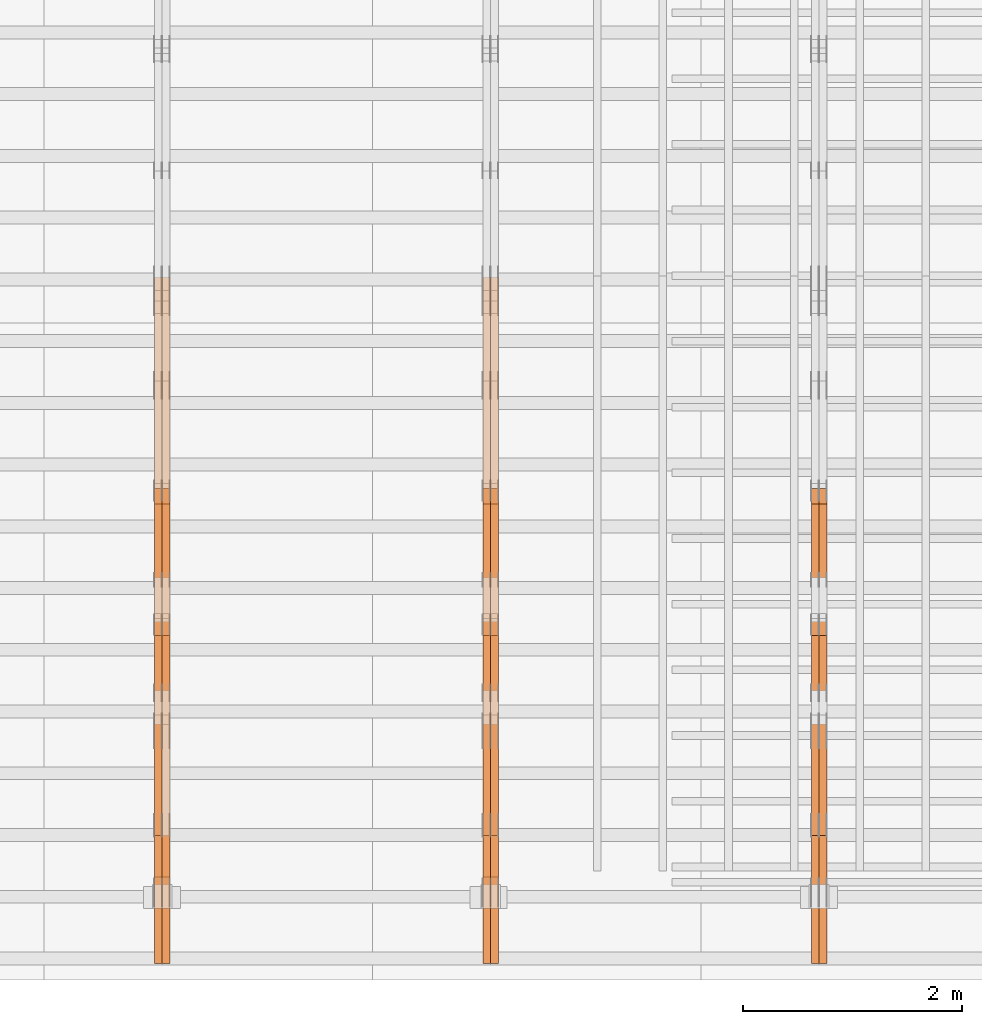
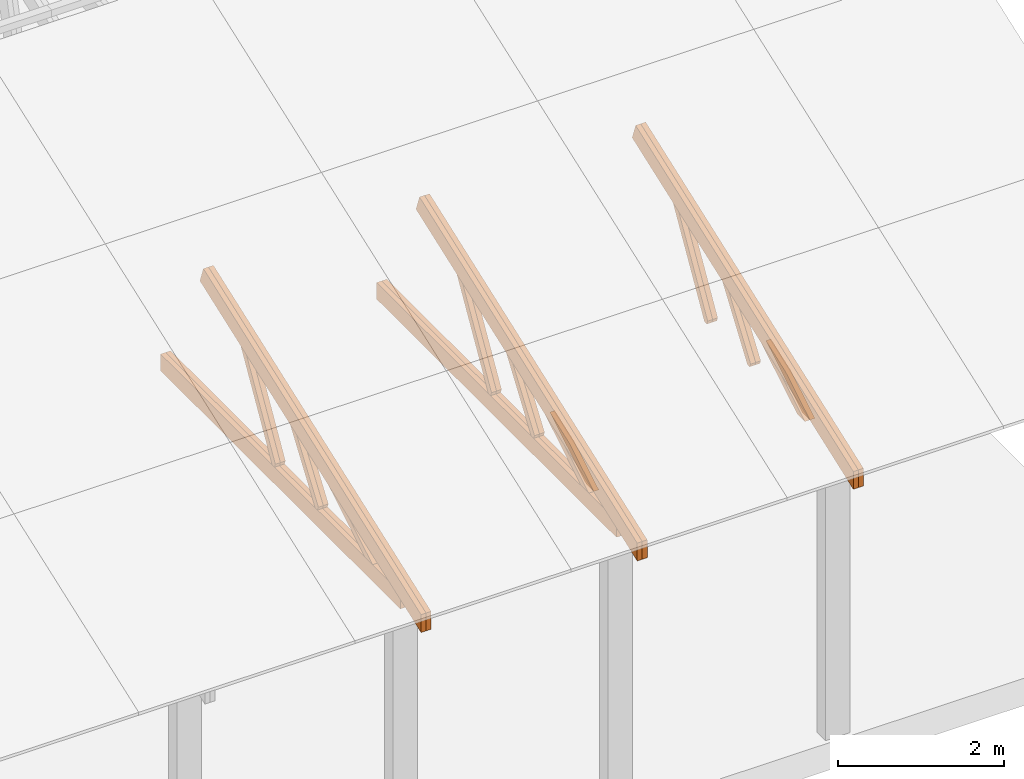
# One storey, part 47 of 189: 27 proxies.
"""IFC2X3 building model written with IfcOpenShell, lengths in millimetres."""

from ifc_helpers import new_model, entity, si_unit, converted_unit, derived_unit, direction, frame, origin, place, context, subcontext, project, spatial, polyline, outline, extrude, source, transform, mapped, material, type_object, type_shapes, element, save


model = new_model("IFC2X3")

# Units and contexts
model_context = context("Model", 3, precision=0.01, world=origin(), true_north=direction((6.12303176911189e-17, 1.0)))
body_context = subcontext(model_context, "Body", "Model", "MODEL_VIEW")
ifc_project = project(units=[si_unit("LENGTHUNIT", "METRE", prefix="MILLI"), si_unit("AREAUNIT", "SQUARE_METRE"), si_unit("VOLUMEUNIT", "CUBIC_METRE"), converted_unit("PLANEANGLEUNIT", "DEGREE", entity("IfcRatioMeasure", 0.0174532925199433), si_unit("PLANEANGLEUNIT", "RADIAN"), dimensions=[0, 0, 0, 0, 0, 0, 0]), si_unit("MASSUNIT", "GRAM", prefix="KILO"), derived_unit("MASSDENSITYUNIT", [(si_unit("MASSUNIT", "GRAM", prefix="KILO"), 1), (si_unit("LENGTHUNIT", "METRE"), -3)]), si_unit("TIMEUNIT", "SECOND"), si_unit("FREQUENCYUNIT", "HERTZ"), si_unit("THERMODYNAMICTEMPERATUREUNIT", "DEGREE_CELSIUS"), derived_unit("THERMALTRANSMITTANCEUNIT", [(si_unit("MASSUNIT", "GRAM", prefix="KILO"), 1), (si_unit("THERMODYNAMICTEMPERATUREUNIT", "KELVIN"), -1), (si_unit("TIMEUNIT", "SECOND"), -3)]), derived_unit("VOLUMETRICFLOWRATEUNIT", [(si_unit("LENGTHUNIT", "METRE"), 3), (si_unit("TIMEUNIT", "SECOND"), -1)]), si_unit("ELECTRICCURRENTUNIT", "AMPERE"), si_unit("ELECTRICVOLTAGEUNIT", "VOLT"), si_unit("POWERUNIT", "WATT"), si_unit("FORCEUNIT", "NEWTON"), si_unit("ILLUMINANCEUNIT", "LUX"), si_unit("LUMINOUSFLUXUNIT", "LUMEN"), si_unit("LUMINOUSINTENSITYUNIT", "CANDELA"), derived_unit("USERDEFINED", [(si_unit("MASSUNIT", "GRAM", prefix="KILO"), -1), (si_unit("LENGTHUNIT", "METRE"), -2), (si_unit("TIMEUNIT", "SECOND"), 3), (si_unit("LUMINOUSFLUXUNIT", "LUMEN"), 1)]), derived_unit("LINEARVELOCITYUNIT", [(si_unit("LENGTHUNIT", "METRE"), 1), (si_unit("TIMEUNIT", "SECOND"), -1)]), si_unit("PRESSUREUNIT", "PASCAL"), derived_unit("USERDEFINED", [(si_unit("LENGTHUNIT", "METRE"), -2), (si_unit("MASSUNIT", "GRAM", prefix="KILO"), 1), (si_unit("TIMEUNIT", "SECOND"), -2)])], contexts=[model_context])

# Site, building, storey
site_placement = place(None, origin())
site = spatial("IfcSite", under=ifc_project, at=site_placement, CompositionType="ELEMENT")
building_placement = place(site_placement, origin())
building = spatial("IfcBuilding", under=site, at=building_placement, CompositionType="ELEMENT")
storey_placement = place(building_placement, origin())
storey = spatial("IfcBuildingStorey", under=building, at=storey_placement, Name="Default", CompositionType="ELEMENT", Elevation=0.0)

# Proxies
ifc_material_1 = material(Name="IfcSurfaceStyle #239684")
building_element_proxy_type_1 = type_object("IfcBuildingElementProxyType", Name="T1-W11 239682", PredefinedType="NOTDEFINED", material=ifc_material_1)
shared_shape_1 = source(origin(), body_context, "Body", "SweptSolid", [
    extrude(outline(polyline([(593.358012843793, -552.565239103314), (742.388662259985, -552.565239103314), (-410.498749190676, 401.275038694583), (-462.246133468927, 382.44069706518), (-463.001792444175, 321.414742446865), (593.358012843793, -552.565239103314)])), frame((599.94412413079, 47.5003788877286, 0.0), z_axis=(0.0, 0.0, 1.0), x_axis=(0.770483455324544, 0.637459994879013, 0.0)), (0.0, 0.0, 1.0), 69.9999999999999),
])
type_shapes(building_element_proxy_type_1, [shared_shape_1])
proxy_1_placement = place(building_placement, frame((45300.0, 2983.26655629375, 269.034992751429), z_axis=(-1.0, 0.0, 0.0), x_axis=(0.0, 0.505995901100606, 0.862535882192379)))
element("IfcBuildingElementProxy", 1, at=proxy_1_placement, inside=storey, type_object=building_element_proxy_type_1, material=ifc_material_1, Name="T1-W11", context=body_context, shape_type="MappedRepresentation", body=[
    mapped(shared_shape_1, transform((0.0, 0.0, 0.0), scale=1.0)),
])
ifc_material_2 = material(Name="IfcSurfaceStyle #239618")
building_element_proxy_type_2 = type_object("IfcBuildingElementProxyType", Name="T1-W11 239616", PredefinedType="NOTDEFINED", material=ifc_material_2)
shared_shape_2 = source(origin(), body_context, "Body", "SweptSolid", [
    extrude(outline(polyline([(593.358012843793, -552.565239103314), (742.388662259985, -552.565239103314), (-410.498749190676, 401.275038694583), (-462.246133468927, 382.44069706518), (-463.001792444175, 321.414742446865), (593.358012843793, -552.565239103314)])), frame((599.94412413079, 47.5003788877286, 0.0), z_axis=(0.0, 0.0, 1.0), x_axis=(0.770483455324544, 0.637459994879013, 0.0)), (0.0, 0.0, 1.0), 69.9999999999999),
])
type_shapes(building_element_proxy_type_2, [shared_shape_2])
proxy_2_placement = place(building_placement, frame((45230.0, 2983.26655629375, 269.034992751429), z_axis=(-1.0, 0.0, 0.0), x_axis=(0.0, 0.505995901100606, 0.862535882192379)))
element("IfcBuildingElementProxy", 2, at=proxy_2_placement, inside=storey, type_object=building_element_proxy_type_2, material=ifc_material_2, Name="T1-W11", context=body_context, shape_type="MappedRepresentation", body=[
    mapped(shared_shape_2, transform((0.0, 0.0, 0.0), scale=1.0)),
])
ifc_material_3 = material(Name="IfcSurfaceStyle #239156")
building_element_proxy_type_3 = type_object("IfcBuildingElementProxyType", Name="T1-W13 239154", PredefinedType="NOTDEFINED", material=ifc_material_3)
shared_shape_3 = source(origin(), body_context, "Body", "SweptSolid", [
    extrude(outline(polyline([(404.740440720218, -341.48092914206), (570.336320797765, -341.48092914206), (-287.911826743206, 259.650691447848), (-342.395697357435, 239.820346030744), (-344.769237417342, 183.490820805529), (404.740440720218, -341.48092914206)])), frame((418.029573061951, 47.5005675782689, 0.0), z_axis=(0.0, 0.0, 1.0), x_axis=(0.819070847746389, 0.573692379565924, 0.0)), (0.0, 0.0, 1.0), 69.9999999999999),
])
type_shapes(building_element_proxy_type_3, [shared_shape_3])
proxy_3_placement = place(building_placement, frame((45300.0, 1951.16403402681, 272.239720286334), z_axis=(-1.0, 0.0, 0.0), x_axis=(0.0, 0.573462629043499, 0.819231721242848)))
element("IfcBuildingElementProxy", 3, at=proxy_3_placement, inside=storey, type_object=building_element_proxy_type_3, material=ifc_material_3, Name="T1-W13", context=body_context, shape_type="MappedRepresentation", body=[
    mapped(shared_shape_3, transform((0.0, 0.0, 0.0), scale=1.0)),
])
ifc_material_4 = material(Name="IfcSurfaceStyle #239090")
building_element_proxy_type_4 = type_object("IfcBuildingElementProxyType", Name="T1-W13 239088", PredefinedType="NOTDEFINED", material=ifc_material_4)
shared_shape_4 = source(origin(), body_context, "Body", "SweptSolid", [
    extrude(outline(polyline([(404.740440720218, -341.48092914206), (570.336320797765, -341.48092914206), (-287.911826743206, 259.650691447848), (-342.395697357435, 239.820346030744), (-344.769237417342, 183.490820805529), (404.740440720218, -341.48092914206)])), frame((418.029573061951, 47.5005675782689, 0.0), z_axis=(0.0, 0.0, 1.0), x_axis=(0.819070847746389, 0.573692379565924, 0.0)), (0.0, 0.0, 1.0), 69.9999999999999),
])
type_shapes(building_element_proxy_type_4, [shared_shape_4])
proxy_4_placement = place(building_placement, frame((45230.0, 1951.16403402681, 272.239720286334), z_axis=(-1.0, 0.0, 0.0), x_axis=(0.0, 0.573462629043499, 0.819231721242848)))
element("IfcBuildingElementProxy", 4, at=proxy_4_placement, inside=storey, type_object=building_element_proxy_type_4, material=ifc_material_4, Name="T1-W13", context=body_context, shape_type="MappedRepresentation", body=[
    mapped(shared_shape_4, transform((0.0, 0.0, 0.0), scale=1.0)),
])
ifc_material_5 = material(Name="IfcSurfaceStyle #238628")
building_element_proxy_type_5 = type_object("IfcBuildingElementProxyType", Name="T1-W12 238626", PredefinedType="NOTDEFINED", material=ifc_material_5)
shared_shape_5 = source(origin(), body_context, "Body", "SweptSolid", [
    extrude(outline(polyline([(-671.888430889784, -47.499785620702), (344.892972119224, -47.499785620702), (503.856463083211, 47.4997856207019), (-176.861004312651, 47.499785620702), (-671.888430889784, -47.499785620702)])), frame((503.857114243549, 47.5002636410509, 0.0), z_axis=(0.0, 0.0, 1.0), x_axis=(-1.0, 0.0, 0.0)), (0.0, 0.0, 1.0), 69.9999999999999),
])
type_shapes(building_element_proxy_type_5, [shared_shape_5])
proxy_5_placement = place(building_placement, frame((45300.0, 665.58122707747, 245.000076287477), z_axis=(-1.0, 0.0, 0.0), x_axis=(0.0, 0.858392121304013, 0.51299411895576)))
element("IfcBuildingElementProxy", 5, at=proxy_5_placement, inside=storey, type_object=building_element_proxy_type_5, material=ifc_material_5, Name="T1-W12", context=body_context, shape_type="MappedRepresentation", body=[
    mapped(shared_shape_5, transform((0.0, 0.0, 0.0), scale=1.0)),
])
ifc_material_6 = material(Name="IfcSurfaceStyle #238571")
building_element_proxy_type_6 = type_object("IfcBuildingElementProxyType", Name="T1-W12 238569", PredefinedType="NOTDEFINED", material=ifc_material_6)
shared_shape_6 = source(origin(), body_context, "Body", "SweptSolid", [
    extrude(outline(polyline([(-671.888430889784, -47.499785620702), (344.892972119224, -47.499785620702), (503.856463083211, 47.4997856207019), (-176.861004312651, 47.499785620702), (-671.888430889784, -47.499785620702)])), frame((503.857114243549, 47.5002636410509, 0.0), z_axis=(0.0, 0.0, 1.0), x_axis=(-1.0, 0.0, 0.0)), (0.0, 0.0, 1.0), 69.9999999999999),
])
type_shapes(building_element_proxy_type_6, [shared_shape_6])
proxy_6_placement = place(building_placement, frame((45230.0, 665.58122707747, 245.000076287477), z_axis=(-1.0, 0.0, 0.0), x_axis=(0.0, 0.858392121304013, 0.51299411895576)))
element("IfcBuildingElementProxy", 6, at=proxy_6_placement, inside=storey, type_object=building_element_proxy_type_6, material=ifc_material_6, Name="T1-W12", context=body_context, shape_type="MappedRepresentation", body=[
    mapped(shared_shape_6, transform((0.0, 0.0, 0.0), scale=1.0)),
])
ifc_material_7 = material(Name="IfcSurfaceStyle #237680")
building_element_proxy_type_7 = type_object("IfcBuildingElementProxyType", Name="T1-T2 237678", PredefinedType="NOTDEFINED", material=ifc_material_7)
shared_shape_7 = source(origin(), body_context, "Body", "SweptSolid", [
    extrude(outline(polyline([(-2763.12044548193, -122.499971764318), (2807.70681121203, -122.499971764318), (2807.70678531127, 122.499971764318), (-2852.29315104137, 122.499971764318), (-2763.12044548193, -122.499971764318)])), frame((2807.70684902043, 122.500023191939, 0.0), z_axis=(0.0, 0.0, 1.0), x_axis=(-1.0, 0.0, 0.0)), (0.0, 0.0, 1.0), 69.9999999999997),
])
type_shapes(building_element_proxy_type_7, [shared_shape_7])
proxy_7_placement = place(building_placement, frame((45300.0, 4818.66023370631, 1893.1253396746), z_axis=(-1.0, 0.0, 0.0), x_axis=(0.0, -0.939692620785908, -0.342020143325669)))
element("IfcBuildingElementProxy", 7, at=proxy_7_placement, inside=storey, type_object=building_element_proxy_type_7, material=ifc_material_7, Name="T1-T2", context=body_context, shape_type="MappedRepresentation", body=[
    mapped(shared_shape_7, transform((0.0, 0.0, 0.0), scale=1.0)),
])
ifc_material_8 = material(Name="IfcSurfaceStyle #237623")
building_element_proxy_type_8 = type_object("IfcBuildingElementProxyType", Name="T1-T2 237621", PredefinedType="NOTDEFINED", material=ifc_material_8)
shared_shape_8 = source(origin(), body_context, "Body", "SweptSolid", [
    extrude(outline(polyline([(-2763.12044548193, -122.499971764318), (2807.70681121203, -122.499971764318), (2807.70678531127, 122.499971764318), (-2852.29315104137, 122.499971764318), (-2763.12044548193, -122.499971764318)])), frame((2807.70684902043, 122.500023191939, 0.0), z_axis=(0.0, 0.0, 1.0), x_axis=(-1.0, 0.0, 0.0)), (0.0, 0.0, 1.0), 69.9999999999997),
])
type_shapes(building_element_proxy_type_8, [shared_shape_8])
proxy_8_placement = place(building_placement, frame((45230.0, 4818.66023370631, 1893.1253396746), z_axis=(-1.0, 0.0, 0.0), x_axis=(0.0, -0.939692620785908, -0.342020143325669)))
element("IfcBuildingElementProxy", 8, at=proxy_8_placement, inside=storey, type_object=building_element_proxy_type_8, material=ifc_material_8, Name="T1-T2", context=body_context, shape_type="MappedRepresentation", body=[
    mapped(shared_shape_8, transform((0.0, 0.0, 0.0), scale=1.0)),
])
ifc_material_9 = material(Name="IfcSurfaceStyle #223894")
building_element_proxy_type_9 = type_object("IfcBuildingElementProxyType", Name="T1-W11 223892", PredefinedType="NOTDEFINED", material=ifc_material_9)
shared_shape_9 = source(origin(), body_context, "Body", "SweptSolid", [
    extrude(outline(polyline([(593.358012843793, -552.565239103314), (742.388662259985, -552.565239103314), (-410.498749190676, 401.275038694583), (-462.246133468927, 382.44069706518), (-463.001792444175, 321.414742446865), (593.358012843793, -552.565239103314)])), frame((599.94412413079, 47.5003788877286, 0.0), z_axis=(0.0, 0.0, 1.0), x_axis=(0.770483455324544, 0.637459994879013, 0.0)), (0.0, 0.0, 1.0), 69.9999999999999),
])
type_shapes(building_element_proxy_type_9, [shared_shape_9])
proxy_9_placement = place(building_placement, frame((42300.0, 2983.26655629375, 269.034992751429), z_axis=(-1.0, 0.0, 0.0), x_axis=(0.0, 0.505995901100606, 0.862535882192379)))
element("IfcBuildingElementProxy", 9, at=proxy_9_placement, inside=storey, type_object=building_element_proxy_type_9, material=ifc_material_9, Name="T1-W11", context=body_context, shape_type="MappedRepresentation", body=[
    mapped(shared_shape_9, transform((0.0, 0.0, 0.0), scale=1.0)),
])
ifc_material_10 = material(Name="IfcSurfaceStyle #223828")
building_element_proxy_type_10 = type_object("IfcBuildingElementProxyType", Name="T1-W11 223826", PredefinedType="NOTDEFINED", material=ifc_material_10)
shared_shape_10 = source(origin(), body_context, "Body", "SweptSolid", [
    extrude(outline(polyline([(593.358012843793, -552.565239103314), (742.388662259985, -552.565239103314), (-410.498749190676, 401.275038694583), (-462.246133468927, 382.44069706518), (-463.001792444175, 321.414742446865), (593.358012843793, -552.565239103314)])), frame((599.94412413079, 47.5003788877286, 0.0), z_axis=(0.0, 0.0, 1.0), x_axis=(0.770483455324544, 0.637459994879013, 0.0)), (0.0, 0.0, 1.0), 69.9999999999999),
])
type_shapes(building_element_proxy_type_10, [shared_shape_10])
proxy_10_placement = place(building_placement, frame((42230.0, 2983.26655629375, 269.034992751429), z_axis=(-1.0, 0.0, 0.0), x_axis=(0.0, 0.505995901100606, 0.862535882192379)))
element("IfcBuildingElementProxy", 10, at=proxy_10_placement, inside=storey, type_object=building_element_proxy_type_10, material=ifc_material_10, Name="T1-W11", context=body_context, shape_type="MappedRepresentation", body=[
    mapped(shared_shape_10, transform((0.0, 0.0, 0.0), scale=1.0)),
])
ifc_material_11 = material(Name="IfcSurfaceStyle #223366")
building_element_proxy_type_11 = type_object("IfcBuildingElementProxyType", Name="T1-W13 223364", PredefinedType="NOTDEFINED", material=ifc_material_11)
shared_shape_11 = source(origin(), body_context, "Body", "SweptSolid", [
    extrude(outline(polyline([(404.740440720218, -341.48092914206), (570.336320797765, -341.48092914206), (-287.911826743206, 259.650691447848), (-342.395697357435, 239.820346030744), (-344.769237417342, 183.490820805529), (404.740440720218, -341.48092914206)])), frame((418.029573061951, 47.5005675782689, 0.0), z_axis=(0.0, 0.0, 1.0), x_axis=(0.819070847746389, 0.573692379565924, 0.0)), (0.0, 0.0, 1.0), 69.9999999999999),
])
type_shapes(building_element_proxy_type_11, [shared_shape_11])
proxy_11_placement = place(building_placement, frame((42300.0, 1951.16403402681, 272.239720286334), z_axis=(-1.0, 0.0, 0.0), x_axis=(0.0, 0.573462629043499, 0.819231721242848)))
element("IfcBuildingElementProxy", 11, at=proxy_11_placement, inside=storey, type_object=building_element_proxy_type_11, material=ifc_material_11, Name="T1-W13", context=body_context, shape_type="MappedRepresentation", body=[
    mapped(shared_shape_11, transform((0.0, 0.0, 0.0), scale=1.0)),
])
ifc_material_12 = material(Name="IfcSurfaceStyle #223300")
building_element_proxy_type_12 = type_object("IfcBuildingElementProxyType", Name="T1-W13 223298", PredefinedType="NOTDEFINED", material=ifc_material_12)
shared_shape_12 = source(origin(), body_context, "Body", "SweptSolid", [
    extrude(outline(polyline([(404.740440720218, -341.48092914206), (570.336320797765, -341.48092914206), (-287.911826743206, 259.650691447848), (-342.395697357435, 239.820346030744), (-344.769237417342, 183.490820805529), (404.740440720218, -341.48092914206)])), frame((418.029573061951, 47.5005675782689, 0.0), z_axis=(0.0, 0.0, 1.0), x_axis=(0.819070847746389, 0.573692379565924, 0.0)), (0.0, 0.0, 1.0), 69.9999999999999),
])
type_shapes(building_element_proxy_type_12, [shared_shape_12])
proxy_12_placement = place(building_placement, frame((42230.0, 1951.16403402681, 272.239720286334), z_axis=(-1.0, 0.0, 0.0), x_axis=(0.0, 0.573462629043499, 0.819231721242848)))
element("IfcBuildingElementProxy", 12, at=proxy_12_placement, inside=storey, type_object=building_element_proxy_type_12, material=ifc_material_12, Name="T1-W13", context=body_context, shape_type="MappedRepresentation", body=[
    mapped(shared_shape_12, transform((0.0, 0.0, 0.0), scale=1.0)),
])
ifc_material_13 = material(Name="IfcSurfaceStyle #222838")
building_element_proxy_type_13 = type_object("IfcBuildingElementProxyType", Name="T1-W12 222836", PredefinedType="NOTDEFINED", material=ifc_material_13)
shared_shape_13 = source(origin(), body_context, "Body", "SweptSolid", [
    extrude(outline(polyline([(-671.888430889784, -47.499785620702), (344.892972119224, -47.499785620702), (503.856463083211, 47.4997856207019), (-176.861004312651, 47.499785620702), (-671.888430889784, -47.499785620702)])), frame((503.857114243549, 47.5002636410509, 0.0), z_axis=(0.0, 0.0, 1.0), x_axis=(-1.0, 0.0, 0.0)), (0.0, 0.0, 1.0), 69.9999999999999),
])
type_shapes(building_element_proxy_type_13, [shared_shape_13])
proxy_13_placement = place(building_placement, frame((42300.0, 665.58122707747, 245.000076287477), z_axis=(-1.0, 0.0, 0.0), x_axis=(0.0, 0.858392121304013, 0.51299411895576)))
element("IfcBuildingElementProxy", 13, at=proxy_13_placement, inside=storey, type_object=building_element_proxy_type_13, material=ifc_material_13, Name="T1-W12", context=body_context, shape_type="MappedRepresentation", body=[
    mapped(shared_shape_13, transform((0.0, 0.0, 0.0), scale=1.0)),
])
ifc_material_14 = material(Name="IfcSurfaceStyle #222781")
building_element_proxy_type_14 = type_object("IfcBuildingElementProxyType", Name="T1-W12 222779", PredefinedType="NOTDEFINED", material=ifc_material_14)
shared_shape_14 = source(origin(), body_context, "Body", "SweptSolid", [
    extrude(outline(polyline([(-671.888430889784, -47.499785620702), (344.892972119224, -47.499785620702), (503.856463083211, 47.4997856207019), (-176.861004312651, 47.499785620702), (-671.888430889784, -47.499785620702)])), frame((503.857114243549, 47.5002636410509, 0.0), z_axis=(0.0, 0.0, 1.0), x_axis=(-1.0, 0.0, 0.0)), (0.0, 0.0, 1.0), 69.9999999999999),
])
type_shapes(building_element_proxy_type_14, [shared_shape_14])
proxy_14_placement = place(building_placement, frame((42230.0, 665.58122707747, 245.000076287477), z_axis=(-1.0, 0.0, 0.0), x_axis=(0.0, 0.858392121304013, 0.51299411895576)))
element("IfcBuildingElementProxy", 14, at=proxy_14_placement, inside=storey, type_object=building_element_proxy_type_14, material=ifc_material_14, Name="T1-W12", context=body_context, shape_type="MappedRepresentation", body=[
    mapped(shared_shape_14, transform((0.0, 0.0, 0.0), scale=1.0)),
])
ifc_material_15 = material(Name="IfcSurfaceStyle #222022")
building_element_proxy_type_15 = type_object("IfcBuildingElementProxyType", Name="T1-B2 222020", PredefinedType="NOTDEFINED", material=ifc_material_15)
shared_shape_15 = source(origin(), body_context, "Body", "SweptSolid", [
    extrude(outline(polyline([(-3399.385546875, -125.855288696291), (2363.08125, -125.855288696291), (2363.08125, 13.4211547851572), (2072.60859375, 119.144711303712), (-3399.385546875, 119.144711303712), (-3399.385546875, -125.855288696291)])), frame((2363.08125, 119.144711303712, 0.0), z_axis=(0.0, 0.0, 1.0), x_axis=(-1.0, 0.0, 0.0)), (0.0, 0.0, 1.0), 69.9999999999997),
])
type_shapes(building_element_proxy_type_15, [shared_shape_15])
proxy_15_placement = place(building_placement, frame((42300.0, 0.0, 245.0), z_axis=(-1.0, 0.0, 0.0), x_axis=(0.0, 1.0, 0.0)))
element("IfcBuildingElementProxy", 15, at=proxy_15_placement, inside=storey, type_object=building_element_proxy_type_15, material=ifc_material_15, Name="T1-B2", context=body_context, shape_type="MappedRepresentation", body=[
    mapped(shared_shape_15, transform((0.0, 0.0, 0.0), scale=1.0)),
])
ifc_material_16 = material(Name="IfcSurfaceStyle #221956")
building_element_proxy_type_16 = type_object("IfcBuildingElementProxyType", Name="T1-B2 221954", PredefinedType="NOTDEFINED", material=ifc_material_16)
shared_shape_16 = source(origin(), body_context, "Body", "SweptSolid", [
    extrude(outline(polyline([(-3399.385546875, -125.855288696291), (2363.08125, -125.855288696291), (2363.08125, 13.4211547851572), (2072.60859375, 119.144711303712), (-3399.385546875, 119.144711303712), (-3399.385546875, -125.855288696291)])), frame((2363.08125, 119.144711303712, 0.0), z_axis=(0.0, 0.0, 1.0), x_axis=(-1.0, 0.0, 0.0)), (0.0, 0.0, 1.0), 69.9999999999997),
])
type_shapes(building_element_proxy_type_16, [shared_shape_16])
proxy_16_placement = place(building_placement, frame((42230.0, 0.0, 245.0), z_axis=(-1.0, 0.0, 0.0), x_axis=(0.0, 1.0, 0.0)))
element("IfcBuildingElementProxy", 16, at=proxy_16_placement, inside=storey, type_object=building_element_proxy_type_16, material=ifc_material_16, Name="T1-B2", context=body_context, shape_type="MappedRepresentation", body=[
    mapped(shared_shape_16, transform((0.0, 0.0, 0.0), scale=1.0)),
])
ifc_material_17 = material(Name="IfcSurfaceStyle #221890")
building_element_proxy_type_17 = type_object("IfcBuildingElementProxyType", Name="T1-T2 221888", PredefinedType="NOTDEFINED", material=ifc_material_17)
shared_shape_17 = source(origin(), body_context, "Body", "SweptSolid", [
    extrude(outline(polyline([(-2763.12044548193, -122.499971764318), (2807.70681121203, -122.499971764318), (2807.70678531127, 122.499971764318), (-2852.29315104137, 122.499971764318), (-2763.12044548193, -122.499971764318)])), frame((2807.70684902043, 122.500023191939, 0.0), z_axis=(0.0, 0.0, 1.0), x_axis=(-1.0, 0.0, 0.0)), (0.0, 0.0, 1.0), 69.9999999999997),
])
type_shapes(building_element_proxy_type_17, [shared_shape_17])
proxy_17_placement = place(building_placement, frame((42300.0, 4818.66023370631, 1893.1253396746), z_axis=(-1.0, 0.0, 0.0), x_axis=(0.0, -0.939692620785908, -0.342020143325669)))
element("IfcBuildingElementProxy", 17, at=proxy_17_placement, inside=storey, type_object=building_element_proxy_type_17, material=ifc_material_17, Name="T1-T2", context=body_context, shape_type="MappedRepresentation", body=[
    mapped(shared_shape_17, transform((0.0, 0.0, 0.0), scale=1.0)),
])
ifc_material_18 = material(Name="IfcSurfaceStyle #221833")
building_element_proxy_type_18 = type_object("IfcBuildingElementProxyType", Name="T1-T2 221831", PredefinedType="NOTDEFINED", material=ifc_material_18)
shared_shape_18 = source(origin(), body_context, "Body", "SweptSolid", [
    extrude(outline(polyline([(-2763.12044548193, -122.499971764318), (2807.70681121203, -122.499971764318), (2807.70678531127, 122.499971764318), (-2852.29315104137, 122.499971764318), (-2763.12044548193, -122.499971764318)])), frame((2807.70684902043, 122.500023191939, 0.0), z_axis=(0.0, 0.0, 1.0), x_axis=(-1.0, 0.0, 0.0)), (0.0, 0.0, 1.0), 69.9999999999997),
])
type_shapes(building_element_proxy_type_18, [shared_shape_18])
proxy_18_placement = place(building_placement, frame((42230.0, 4818.66023370631, 1893.1253396746), z_axis=(-1.0, 0.0, 0.0), x_axis=(0.0, -0.939692620785908, -0.342020143325669)))
element("IfcBuildingElementProxy", 18, at=proxy_18_placement, inside=storey, type_object=building_element_proxy_type_18, material=ifc_material_18, Name="T1-T2", context=body_context, shape_type="MappedRepresentation", body=[
    mapped(shared_shape_18, transform((0.0, 0.0, 0.0), scale=1.0)),
])
ifc_material_19 = material(Name="IfcSurfaceStyle #208104")
building_element_proxy_type_19 = type_object("IfcBuildingElementProxyType", Name="T1-W11 208102", PredefinedType="NOTDEFINED", material=ifc_material_19)
shared_shape_19 = source(origin(), body_context, "Body", "SweptSolid", [
    extrude(outline(polyline([(593.358012843793, -552.565239103314), (742.388662259985, -552.565239103314), (-410.498749190676, 401.275038694583), (-462.246133468927, 382.44069706518), (-463.001792444175, 321.414742446865), (593.358012843793, -552.565239103314)])), frame((599.94412413079, 47.5003788877286, 0.0), z_axis=(0.0, 0.0, 1.0), x_axis=(0.770483455324544, 0.637459994879013, 0.0)), (0.0, 0.0, 1.0), 69.9999999999999),
])
type_shapes(building_element_proxy_type_19, [shared_shape_19])
proxy_19_placement = place(building_placement, frame((39300.0, 2983.26655629375, 269.034992751429), z_axis=(-1.0, 0.0, 0.0), x_axis=(0.0, 0.505995901100606, 0.862535882192379)))
element("IfcBuildingElementProxy", 19, at=proxy_19_placement, inside=storey, type_object=building_element_proxy_type_19, material=ifc_material_19, Name="T1-W11", context=body_context, shape_type="MappedRepresentation", body=[
    mapped(shared_shape_19, transform((0.0, 0.0, 0.0), scale=1.0)),
])
ifc_material_20 = material(Name="IfcSurfaceStyle #208038")
building_element_proxy_type_20 = type_object("IfcBuildingElementProxyType", Name="T1-W11 208036", PredefinedType="NOTDEFINED", material=ifc_material_20)
shared_shape_20 = source(origin(), body_context, "Body", "SweptSolid", [
    extrude(outline(polyline([(593.358012843793, -552.565239103314), (742.388662259985, -552.565239103314), (-410.498749190676, 401.275038694583), (-462.246133468927, 382.44069706518), (-463.001792444175, 321.414742446865), (593.358012843793, -552.565239103314)])), frame((599.94412413079, 47.5003788877286, 0.0), z_axis=(0.0, 0.0, 1.0), x_axis=(0.770483455324544, 0.637459994879013, 0.0)), (0.0, 0.0, 1.0), 69.9999999999999),
])
type_shapes(building_element_proxy_type_20, [shared_shape_20])
proxy_20_placement = place(building_placement, frame((39230.0, 2983.26655629375, 269.034992751429), z_axis=(-1.0, 0.0, 0.0), x_axis=(0.0, 0.505995901100606, 0.862535882192379)))
element("IfcBuildingElementProxy", 20, at=proxy_20_placement, inside=storey, type_object=building_element_proxy_type_20, material=ifc_material_20, Name="T1-W11", context=body_context, shape_type="MappedRepresentation", body=[
    mapped(shared_shape_20, transform((0.0, 0.0, 0.0), scale=1.0)),
])
ifc_material_21 = material(Name="IfcSurfaceStyle #207576")
building_element_proxy_type_21 = type_object("IfcBuildingElementProxyType", Name="T1-W13 207574", PredefinedType="NOTDEFINED", material=ifc_material_21)
shared_shape_21 = source(origin(), body_context, "Body", "SweptSolid", [
    extrude(outline(polyline([(404.740440720218, -341.48092914206), (570.336320797765, -341.48092914206), (-287.911826743206, 259.650691447848), (-342.395697357435, 239.820346030744), (-344.769237417342, 183.490820805529), (404.740440720218, -341.48092914206)])), frame((418.029573061951, 47.5005675782689, 0.0), z_axis=(0.0, 0.0, 1.0), x_axis=(0.819070847746389, 0.573692379565924, 0.0)), (0.0, 0.0, 1.0), 69.9999999999999),
])
type_shapes(building_element_proxy_type_21, [shared_shape_21])
proxy_21_placement = place(building_placement, frame((39300.0, 1951.16403402681, 272.239720286334), z_axis=(-1.0, 0.0, 0.0), x_axis=(0.0, 0.573462629043499, 0.819231721242848)))
element("IfcBuildingElementProxy", 21, at=proxy_21_placement, inside=storey, type_object=building_element_proxy_type_21, material=ifc_material_21, Name="T1-W13", context=body_context, shape_type="MappedRepresentation", body=[
    mapped(shared_shape_21, transform((0.0, 0.0, 0.0), scale=1.0)),
])
ifc_material_22 = material(Name="IfcSurfaceStyle #207510")
building_element_proxy_type_22 = type_object("IfcBuildingElementProxyType", Name="T1-W13 207508", PredefinedType="NOTDEFINED", material=ifc_material_22)
shared_shape_22 = source(origin(), body_context, "Body", "SweptSolid", [
    extrude(outline(polyline([(404.740440720218, -341.48092914206), (570.336320797765, -341.48092914206), (-287.911826743206, 259.650691447848), (-342.395697357435, 239.820346030744), (-344.769237417342, 183.490820805529), (404.740440720218, -341.48092914206)])), frame((418.029573061951, 47.5005675782689, 0.0), z_axis=(0.0, 0.0, 1.0), x_axis=(0.819070847746389, 0.573692379565924, 0.0)), (0.0, 0.0, 1.0), 69.9999999999999),
])
type_shapes(building_element_proxy_type_22, [shared_shape_22])
proxy_22_placement = place(building_placement, frame((39230.0, 1951.16403402681, 272.239720286334), z_axis=(-1.0, 0.0, 0.0), x_axis=(0.0, 0.573462629043499, 0.819231721242848)))
element("IfcBuildingElementProxy", 22, at=proxy_22_placement, inside=storey, type_object=building_element_proxy_type_22, material=ifc_material_22, Name="T1-W13", context=body_context, shape_type="MappedRepresentation", body=[
    mapped(shared_shape_22, transform((0.0, 0.0, 0.0), scale=1.0)),
])
ifc_material_23 = material(Name="IfcSurfaceStyle #206991")
building_element_proxy_type_23 = type_object("IfcBuildingElementProxyType", Name="T1-W12 206989", PredefinedType="NOTDEFINED", material=ifc_material_23)
shared_shape_23 = source(origin(), body_context, "Body", "SweptSolid", [
    extrude(outline(polyline([(-671.888430889784, -47.499785620702), (344.892972119224, -47.499785620702), (503.856463083211, 47.4997856207019), (-176.861004312651, 47.499785620702), (-671.888430889784, -47.499785620702)])), frame((503.857114243549, 47.5002636410509, 0.0), z_axis=(0.0, 0.0, 1.0), x_axis=(-1.0, 0.0, 0.0)), (0.0, 0.0, 1.0), 69.9999999999999),
])
type_shapes(building_element_proxy_type_23, [shared_shape_23])
proxy_23_placement = place(building_placement, frame((39230.0, 665.58122707747, 245.000076287477), z_axis=(-1.0, 0.0, 0.0), x_axis=(0.0, 0.858392121304013, 0.51299411895576)))
element("IfcBuildingElementProxy", 23, at=proxy_23_placement, inside=storey, type_object=building_element_proxy_type_23, material=ifc_material_23, Name="T1-W12", context=body_context, shape_type="MappedRepresentation", body=[
    mapped(shared_shape_23, transform((0.0, 0.0, 0.0), scale=1.0)),
])
ifc_material_24 = material(Name="IfcSurfaceStyle #206232")
building_element_proxy_type_24 = type_object("IfcBuildingElementProxyType", Name="T1-B2 206230", PredefinedType="NOTDEFINED", material=ifc_material_24)
shared_shape_24 = source(origin(), body_context, "Body", "SweptSolid", [
    extrude(outline(polyline([(-3399.385546875, -125.855288696291), (2363.08125, -125.855288696291), (2363.08125, 13.4211547851572), (2072.60859375, 119.144711303712), (-3399.385546875, 119.144711303712), (-3399.385546875, -125.855288696291)])), frame((2363.08125, 119.144711303712, 0.0), z_axis=(0.0, 0.0, 1.0), x_axis=(-1.0, 0.0, 0.0)), (0.0, 0.0, 1.0), 69.9999999999997),
])
type_shapes(building_element_proxy_type_24, [shared_shape_24])
proxy_24_placement = place(building_placement, frame((39300.0, 0.0, 245.0), z_axis=(-1.0, 0.0, 0.0), x_axis=(0.0, 1.0, 0.0)))
element("IfcBuildingElementProxy", 24, at=proxy_24_placement, inside=storey, type_object=building_element_proxy_type_24, material=ifc_material_24, Name="T1-B2", context=body_context, shape_type="MappedRepresentation", body=[
    mapped(shared_shape_24, transform((0.0, 0.0, 0.0), scale=1.0)),
])
ifc_material_25 = material(Name="IfcSurfaceStyle #206166")
building_element_proxy_type_25 = type_object("IfcBuildingElementProxyType", Name="T1-B2 206164", PredefinedType="NOTDEFINED", material=ifc_material_25)
shared_shape_25 = source(origin(), body_context, "Body", "SweptSolid", [
    extrude(outline(polyline([(-3399.385546875, -125.855288696291), (2363.08125, -125.855288696291), (2363.08125, 13.4211547851572), (2072.60859375, 119.144711303712), (-3399.385546875, 119.144711303712), (-3399.385546875, -125.855288696291)])), frame((2363.08125, 119.144711303712, 0.0), z_axis=(0.0, 0.0, 1.0), x_axis=(-1.0, 0.0, 0.0)), (0.0, 0.0, 1.0), 69.9999999999997),
])
type_shapes(building_element_proxy_type_25, [shared_shape_25])
proxy_25_placement = place(building_placement, frame((39230.0, 0.0, 245.0), z_axis=(-1.0, 0.0, 0.0), x_axis=(0.0, 1.0, 0.0)))
element("IfcBuildingElementProxy", 25, at=proxy_25_placement, inside=storey, type_object=building_element_proxy_type_25, material=ifc_material_25, Name="T1-B2", context=body_context, shape_type="MappedRepresentation", body=[
    mapped(shared_shape_25, transform((0.0, 0.0, 0.0), scale=1.0)),
])
ifc_material_26 = material(Name="IfcSurfaceStyle #206100")
building_element_proxy_type_26 = type_object("IfcBuildingElementProxyType", Name="T1-T2 206098", PredefinedType="NOTDEFINED", material=ifc_material_26)
shared_shape_26 = source(origin(), body_context, "Body", "SweptSolid", [
    extrude(outline(polyline([(-2763.12044548193, -122.499971764318), (2807.70681121203, -122.499971764318), (2807.70678531127, 122.499971764318), (-2852.29315104137, 122.499971764318), (-2763.12044548193, -122.499971764318)])), frame((2807.70684902043, 122.500023191939, 0.0), z_axis=(0.0, 0.0, 1.0), x_axis=(-1.0, 0.0, 0.0)), (0.0, 0.0, 1.0), 69.9999999999997),
])
type_shapes(building_element_proxy_type_26, [shared_shape_26])
proxy_26_placement = place(building_placement, frame((39300.0, 4818.66023370631, 1893.1253396746), z_axis=(-1.0, 0.0, 0.0), x_axis=(0.0, -0.939692620785908, -0.342020143325669)))
element("IfcBuildingElementProxy", 26, at=proxy_26_placement, inside=storey, type_object=building_element_proxy_type_26, material=ifc_material_26, Name="T1-T2", context=body_context, shape_type="MappedRepresentation", body=[
    mapped(shared_shape_26, transform((0.0, 0.0, 0.0), scale=1.0)),
])
ifc_material_27 = material(Name="IfcSurfaceStyle #206043")
building_element_proxy_type_27 = type_object("IfcBuildingElementProxyType", Name="T1-T2 206041", PredefinedType="NOTDEFINED", material=ifc_material_27)
shared_shape_27 = source(origin(), body_context, "Body", "SweptSolid", [
    extrude(outline(polyline([(-2763.12044548193, -122.499971764318), (2807.70681121203, -122.499971764318), (2807.70678531127, 122.499971764318), (-2852.29315104137, 122.499971764318), (-2763.12044548193, -122.499971764318)])), frame((2807.70684902043, 122.500023191939, 0.0), z_axis=(0.0, 0.0, 1.0), x_axis=(-1.0, 0.0, 0.0)), (0.0, 0.0, 1.0), 69.9999999999997),
])
type_shapes(building_element_proxy_type_27, [shared_shape_27])
proxy_27_placement = place(building_placement, frame((39230.0, 4818.66023370631, 1893.1253396746), z_axis=(-1.0, 0.0, 0.0), x_axis=(0.0, -0.939692620785908, -0.342020143325669)))
element("IfcBuildingElementProxy", 27, at=proxy_27_placement, inside=storey, type_object=building_element_proxy_type_27, material=ifc_material_27, Name="T1-T2", context=body_context, shape_type="MappedRepresentation", body=[
    mapped(shared_shape_27, transform((0.0, 0.0, 0.0), scale=1.0)),
])

save(model, "model.ifc")
